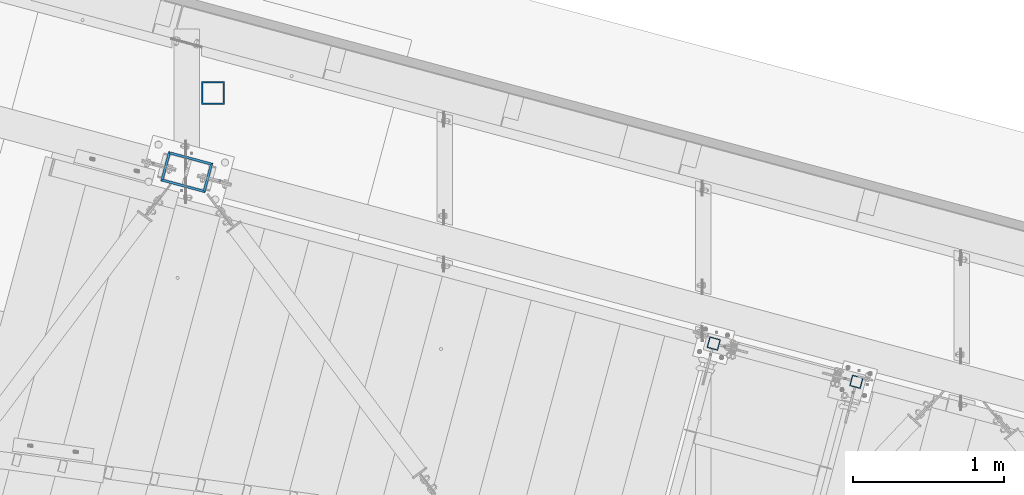
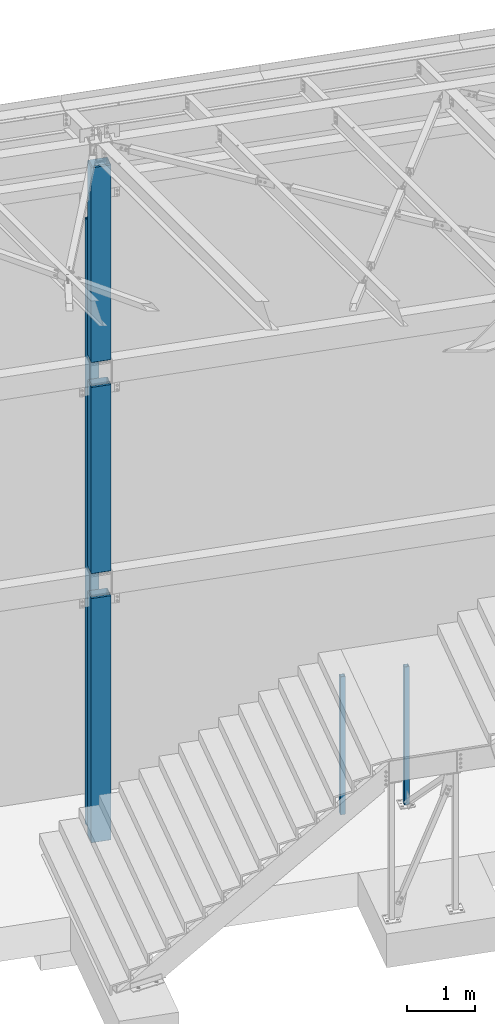
# One storey, part 916 of 1763: 6 columns, 4 elements without a shape of their own.
"""IFC2X3 building model written with IfcOpenShell, lengths in millimetres."""

from ifc_helpers import new_model, si_unit, frame, origin_with_axes, place, context, subcontext, project, spatial, faceted_brep, material, type_object, element, aggregate, save


model = new_model("IFC2X3")

# Units and contexts
model_context = context("Model", 3, precision=1e-05, world=origin_with_axes())
body_context = subcontext(model_context, "Body", "Model", "MODEL_VIEW")
ifc_project = project(units=[si_unit("LENGTHUNIT", "METRE", prefix="MILLI"), si_unit("AREAUNIT", "SQUARE_METRE"), si_unit("VOLUMEUNIT", "CUBIC_METRE"), si_unit("MASSUNIT", "GRAM", prefix="KILO"), si_unit("TIMEUNIT", "SECOND"), si_unit("PLANEANGLEUNIT", "RADIAN"), si_unit("SOLIDANGLEUNIT", "STERADIAN"), si_unit("THERMODYNAMICTEMPERATUREUNIT", "DEGREE_CELSIUS"), si_unit("LUMINOUSINTENSITYUNIT", "LUMEN")], contexts=[model_context])

# Site, building, storey
site_placement = place(None, origin_with_axes())
site = spatial("IfcSite", under=ifc_project, at=site_placement, CompositionType="ELEMENT")
building_placement = place(site_placement, origin_with_axes())
building = spatial("IfcBuilding", under=site, at=building_placement, Name="Undefined", CompositionType="ELEMENT")
storey_placement = place(building_placement, origin_with_axes())
storey = spatial("IfcBuildingStorey", under=building, at=storey_placement, Name="Undefined", CompositionType="ELEMENT", Elevation=0.0)

# Assembly, columns
assembly_1_placement = place(storey_placement, origin_with_axes())
assembly_1 = element("IfcElementAssembly", 1, at=assembly_1_placement, inside=storey, Name="COLUMN", AssemblyPlace="NOTDEFINED", PredefinedType="RIGID_FRAME")
ifc_material = material()
column_type_1 = type_object("IfcColumnType", Name="HSS12X8X5/8", PredefinedType="NOTDEFINED")
column_1_placement = place(assembly_1_placement, frame((-31109.309617316, 64386.9589945012, 8483.6), z_axis=(-0.965913267114846, 0.258865912030774, 0.0), x_axis=(0.0, 0.0, 1.0)))
column_1 = element("IfcColumn", 2, at=column_1_placement, type_object=column_type_1, material=ifc_material, Name="COLUMN", ObjectType="HSS12X8X5/8", context=body_context, shape_type="Brep", body=[
    faceted_brep([(22.2250001691827, -101.599999999904, -152.40000000006), (6.35000000000036, -85.7249999999112, -136.525000000045), (6.35000000000036, 85.7250000000859, -136.524999999936), (22.22500016919, 101.600000000093, -152.399999999921), (22.2249997738745, -101.599999773942, 152.400000112088), (6.35000000000036, -85.7250000000786, 136.524999999943), (22.2249996600258, 101.599999999904, 152.40000000006), (6.35000000000036, 85.7249999999112, 136.525000000045), (3549.64999997895, 85.7249999999112, 136.525000000045), (3549.64999997905, -85.7250000000786, 136.524999999943), (3549.64999989041, -85.7249999999112, -136.525000000045), (3549.64999984625, 85.7250000000859, -136.524999999936), (3533.77500004536, 101.599999999904, 152.40000000006), (3533.77499965904, 101.600000000093, -152.399999999921), (3533.77499965725, -101.599999999904, -152.40000000006), (3533.77500004478, -101.599999998667, 152.400000000634)], [[[0, 1, 2, 3]], [[4, 5, 1, 0]], [[6, 7, 5, 4]], [[5, 7, 8, 9]], [[1, 5, 9, 10]], [[2, 1, 10, 11]], [[7, 2, 11, 8]], [[6, 3, 2, 7]], [[3, 6, 12, 13]], [[0, 3, 13, 14]], [[4, 0, 14, 15]], [[6, 4, 15, 12]], [[8, 12, 15, 9]], [[13, 12, 8, 11]], [[14, 13, 11, 10]], [[15, 14, 10, 9]], [[11, 8, 11, 10, 9, 10]]]),
])
column_2_placement = place(assembly_1_placement, frame((-31109.3096174484, 64386.9589945366, 4673.6), z_axis=(-0.965913267114846, 0.258865912030774, 0.0), x_axis=(0.0, 0.0, 1.0)))
column_2 = element("IfcColumn", 3, at=column_2_placement, type_object=column_type_1, material=ifc_material, Name="COLUMN", ObjectType="HSS12X8X5/8", context=body_context, shape_type="Brep", body=[
    faceted_brep([(3397.25, 85.7249999999185, 136.525000000045), (3397.25, 85.7250000000859, -136.524999999936), (3381.37499999995, 101.600000000093, -152.399999999921), (3381.37500000165, 101.599999999904, 152.40000000006), (3397.25, -85.724999999904, -136.525000000045), (3381.37499999999, -101.599999999897, -152.40000000006), (3397.25, -85.7250000001004, 136.524999999914), (3381.37500000178, -101.600000000079, 152.399999999929), (22.2250001691827, -101.599999999904, -152.40000000006), (6.35000000000036, -85.7249999999112, -136.525000000045), (6.35000000000036, 85.7250000000859, -136.524999999936), (22.22500016919, 101.600000000093, -152.399999999921), (22.2249997738745, -101.599999773942, 152.400000112088), (6.35000000000036, -85.7250000000786, 136.524999999943), (22.2249996600258, 101.599999999904, 152.40000000006), (6.35000000000036, 85.7249999999112, 136.525000000045)], [[[0, 1, 2, 3]], [[4, 5, 2, 1]], [[6, 7, 5, 4]], [[8, 9, 10, 11]], [[12, 13, 9, 8]], [[14, 15, 13, 12]], [[13, 15, 0, 6]], [[9, 13, 6, 4]], [[10, 9, 4, 1]], [[15, 10, 1, 0]], [[14, 11, 10, 15]], [[11, 14, 3, 2]], [[8, 11, 2, 5]], [[12, 8, 5, 7]], [[14, 12, 7, 3]], [[0, 3, 7, 6]]]),
])
column_3_placement = place(assembly_1_placement, frame((-31109.3096174145, 64386.9589945276, -304.799999999999), z_axis=(-0.965913267114846, 0.258865912030774, 0.0), x_axis=(0.0, 0.0, 1.0)))
column_3 = element("IfcColumn", 4, at=column_3_placement, type_object=column_type_1, material=ifc_material, Name="COLUMN", ObjectType="HSS12X8X5/8", context=body_context, shape_type="Brep", body=[
    faceted_brep([(146.049999998875, 101.599999999904, 152.40000000006), (146.050000000008, 101.6000000001, -152.399999999921), (133.349999999999, 88.9000000001033, -139.69999999991), (133.349999999999, 88.9000000002707, 139.700000000703), (146.050000000045, -101.599999999897, -152.40000000006), (133.349999999999, -88.8999999998487, -139.700000000019), (146.04999999961, -101.599999999642, 152.399999999507), (133.349999999999, -88.9000000004235, 139.700000000703), (133.349999999999, 85.7249999999185, 136.525000000045), (133.349999999999, 85.7250000000931, -136.524999999936), (4565.65, 85.7250000000786, -136.524999999936), (4565.65, 85.7249999999112, 136.525000000045), (133.349999999999, -85.7250000000786, 136.524999999936), (4565.65000001169, -85.724999988437, 136.525000023285), (133.349999999999, -85.724999999904, -136.525000000045), (4565.65, -85.7249999999112, -136.525000000045), (4549.77500003684, -101.600000000093, 152.399999999921), (4549.77499998247, -101.599999999897, -152.40000000006), (4549.77500003671, 101.599999999904, 152.400000000052), (4549.7749999824, 101.600000000093, -152.399999999929)], [[[0, 1, 2, 3]], [[4, 5, 2, 1]], [[6, 7, 5, 4]], [[8, 9, 10, 11]], [[12, 8, 11, 13]], [[14, 12, 13, 15]], [[13, 16, 17, 15]], [[11, 18, 16, 13]], [[16, 18, 0, 6]], [[17, 16, 6, 4]], [[19, 17, 4, 1]], [[18, 19, 1, 0]], [[11, 10, 19, 18]], [[15, 17, 19, 10]], [[9, 14, 15, 10]], [[3, 2, 5, 7], [8, 12, 14, 9]], [[0, 3, 7, 6]]]),
])
aggregate(assembly_1, [column_1, column_2, column_3])

# Assembly, column
assembly_2_placement = place(storey_placement, origin_with_axes())
assembly_2 = element("IfcElementAssembly", 5, at=assembly_2_placement, inside=storey, Name="COLUMN", AssemblyPlace="NOTDEFINED", PredefinedType="RIGID_FRAME")
column_type_2 = type_object("IfcColumnType", Name="HSS6X6X3/8", PredefinedType="NOTDEFINED")
column_4_placement = place(assembly_2_placement, frame((-30934.6896174484, 64910.8160179728, -304.8), z_axis=(-1.0, 0.0, 0.0), x_axis=(0.0, 0.0, 1.0)))
column_4 = element("IfcColumn", 6, at=column_4_placement, type_object=column_type_2, material=ifc_material, Name="COLUMN", ObjectType="HSS6X6X3/8", context=body_context, shape_type="Brep", body=[
    faceted_brep([(0.0, 66.6749999999993, -66.6749999999993), (0.0, -66.6750000000029, -66.6749999999993), (10934.7, -66.6750000000029, -66.6749999999993), (10934.7, 66.6750000000029, -66.6749999999993), (0.0, -66.6750000000029, 66.6749999999993), (10934.7, -66.6750000000029, 66.6749999999993), (0.0, 66.6750000000029, 66.6749999999993), (10934.7, 66.6750000000029, 66.6749999999993), (9.09494701772928e-13, 76.2000000000007, -76.2000000000844), (0.0, 76.2000000000007, 76.2000000000771), (10934.7, 76.1999999999971, 76.2000000000007), (10934.7, 76.1999999999971, -76.2000000000007), (0.0, -76.1999999999971, 76.1999999999971), (10934.7, -76.1999999999971, 76.2000000000007), (9.09494701772928e-13, -76.2000000000007, -76.2000000000844), (10934.7, -76.1999999999971, -76.2000000000007)], [[[0, 1, 2, 3]], [[1, 4, 5, 2]], [[4, 6, 7, 5]], [[6, 0, 3, 7]], [[8, 9, 10, 11]], [[9, 12, 13, 10]], [[12, 14, 15, 13]], [[14, 8, 11, 15]], [[13, 15, 11, 10], [5, 7, 3, 2]], [[14, 12, 9, 8], [6, 4, 1, 0]]]),
])
aggregate(assembly_2, [column_4])

assembly_3_placement = place(storey_placement, origin_with_axes())
assembly_3 = element("IfcElementAssembly", 7, at=assembly_3_placement, inside=storey, Name="COLUMN", AssemblyPlace="NOTDEFINED", PredefinedType="RIGID_FRAME")
column_type_3 = type_object("IfcColumnType", Name="HSS3X3X1/4", PredefinedType="NOTDEFINED")
column_5_placement = place(assembly_3_placement, frame((-27619.8239554956, 63251.4510329328, -304.8), z_axis=(-0.965925827679309, 0.258819039914073, 0.0), x_axis=(0.0, 0.0, 1.0)))
column_5 = element("IfcColumn", 8, at=column_5_placement, type_object=column_type_3, material=ifc_material, Name="COLUMN", ObjectType="HSS3X3X1/4", context=body_context, shape_type="Brep", body=[
    faceted_brep([(50.8000000000044, 31.7500000001673, -31.7499999999709), (50.8000000000044, -31.7500000000291, -31.7499999999272), (2540.00000008273, -31.7500000000291, -31.7499999999272), (2540.00000008273, 31.7500000001673, -31.7499999999709), (50.8000000000044, -31.7500000001601, 31.7499999999854), (2540.00000008273, -31.7500000001601, 31.7499999999854), (50.8000000000044, 31.7500000000509, 31.7499999999418), (2540.00000008273, 31.7500000000509, 31.7499999999418), (50.8000000000044, 38.100000000195, -38.0999999999694), (50.8000000000044, 38.1000000000495, 38.0999999999331), (2540.00000008273, 38.1000000000495, 38.0999999999331), (2540.00000008273, 38.100000000195, -38.0999999999694), (50.8000000000044, -38.1000000001804, 38.099999999984), (2540.00000008273, -38.1000000001804, 38.099999999984), (50.8000000000044, -38.1000000000349, -38.0999999999112), (2540.00000008273, -38.1000000000349, -38.0999999999112)], [[[0, 1, 2, 3]], [[1, 4, 5, 2]], [[4, 6, 7, 5]], [[6, 0, 3, 7]], [[8, 9, 10, 11]], [[9, 12, 13, 10]], [[12, 14, 15, 13]], [[14, 8, 11, 15]], [[13, 15, 11, 10], [5, 7, 3, 2]], [[14, 12, 9, 8], [6, 4, 1, 0]]]),
])
aggregate(assembly_3, [column_5])

assembly_4_placement = place(storey_placement, origin_with_axes())
assembly_4 = element("IfcElementAssembly", 9, at=assembly_4_placement, inside=storey, Name="COLUMN", AssemblyPlace="NOTDEFINED", PredefinedType="RIGID_FRAME")
column_6_placement = place(assembly_4_placement, frame((-26675.257371584, 62998.3060575579, -304.800000000001), z_axis=(-0.965925827679309, 0.258819039914073, 0.0), x_axis=(0.0, 0.0, 1.0)))
column_6 = element("IfcColumn", 10, at=column_6_placement, type_object=column_type_3, material=ifc_material, Name="COLUMN", ObjectType="HSS3X3X1/4", context=body_context, shape_type="Brep", body=[
    faceted_brep([(50.8000000000044, 31.7500000001673, -31.7499999999709), (50.8000000000044, -31.7500000000291, -31.7499999999272), (2540.00000008273, -31.7500000000291, -31.7499999999272), (2540.00000008273, 31.7500000001673, -31.7499999999709), (50.8000000000044, -31.7500000001601, 31.7499999999854), (2540.00000008273, -31.7500000001601, 31.7499999999854), (50.8000000000044, 31.7500000000509, 31.7499999999418), (2540.00000008273, 31.7500000000509, 31.7499999999418), (50.8000000000044, 38.100000000195, -38.0999999999694), (50.8000000000044, 38.1000000000495, 38.0999999999331), (2540.00000008273, 38.1000000000495, 38.0999999999331), (2540.00000008273, 38.100000000195, -38.0999999999694), (50.8000000000044, -38.1000000001804, 38.099999999984), (2540.00000008273, -38.1000000001804, 38.099999999984), (50.8000000000044, -38.1000000000349, -38.0999999999112), (2540.00000008273, -38.1000000000349, -38.0999999999112)], [[[0, 1, 2, 3]], [[1, 4, 5, 2]], [[4, 6, 7, 5]], [[6, 0, 3, 7]], [[8, 9, 10, 11]], [[9, 12, 13, 10]], [[12, 14, 15, 13]], [[14, 8, 11, 15]], [[13, 15, 11, 10], [5, 7, 3, 2]], [[14, 12, 9, 8], [6, 4, 1, 0]]]),
])
aggregate(assembly_4, [column_6])

save(model, "model.ifc")
